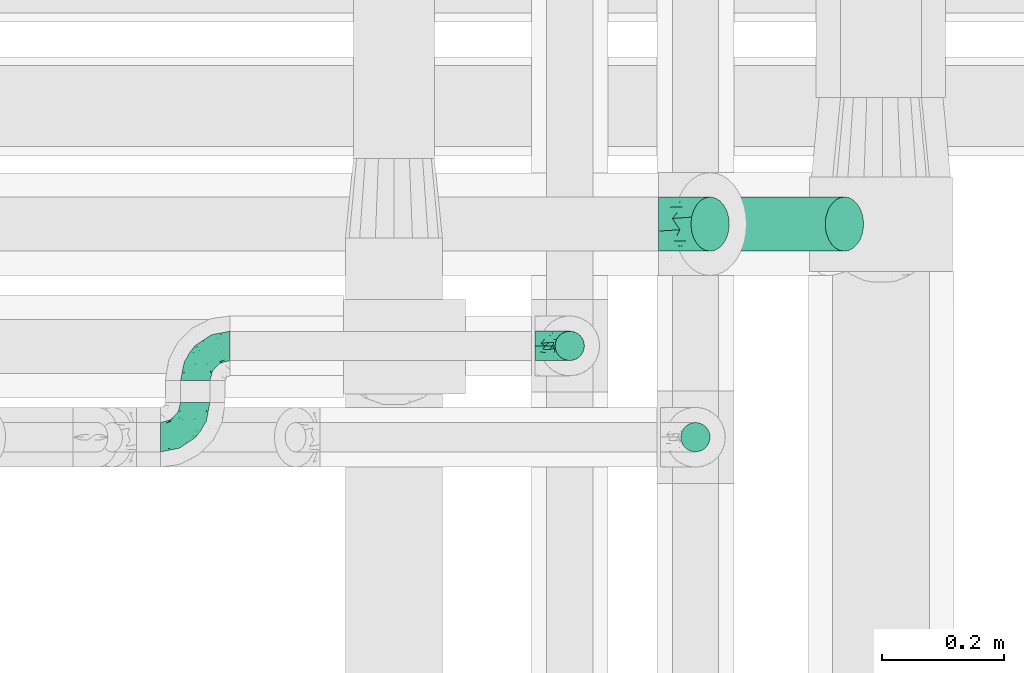
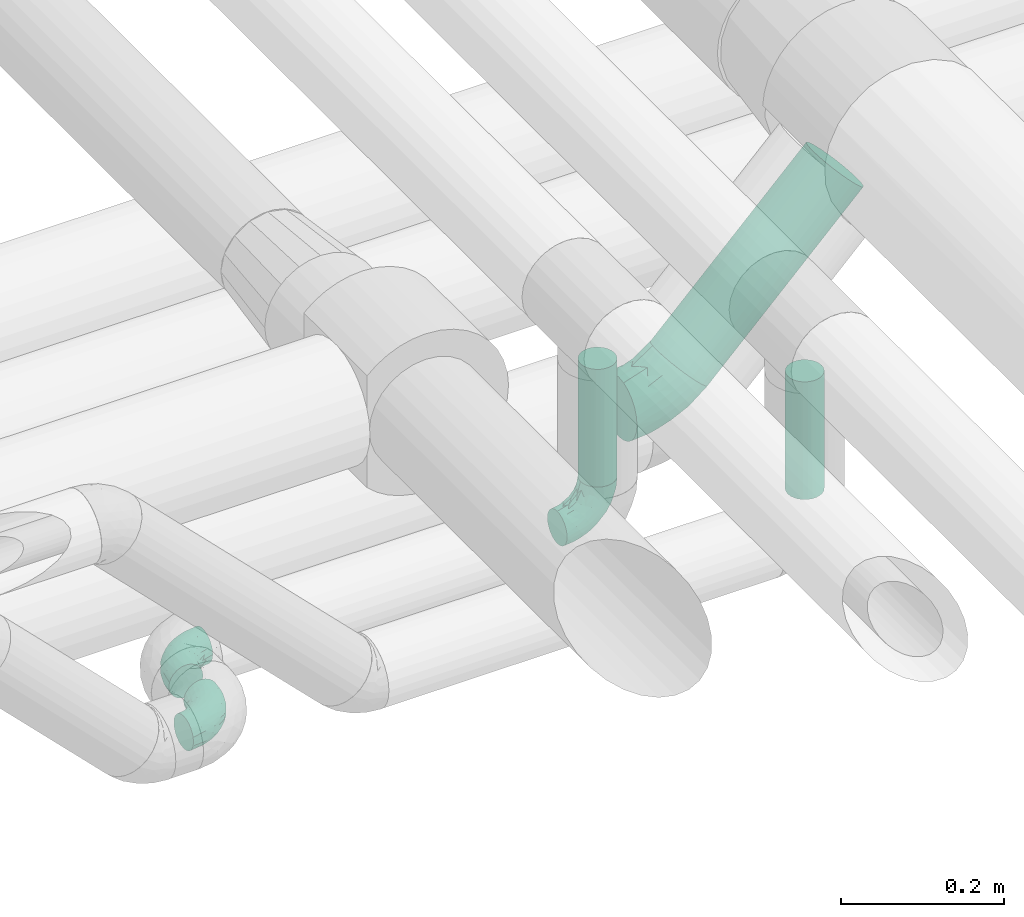
# One storey, part 67 of 93: 4 flow fittings, 3 flow segments.
"""IFC2X3 building model written with IfcOpenShell, lengths in millimetres."""

from ifc_helpers import new_model, entity, si_unit, converted_unit, derived_unit, direction, frame, origin, origin_2d_with_axis, place, context, subcontext, project, spatial, circle, extrude, faceted_brep, source, transform, mapped, material, type_object, type_shapes, element, save


model = new_model("IFC2X3")

# Units and contexts
model_context = context("Model", 3, precision=0.01, world=origin(), true_north=direction((6.12303176911189e-17, 1.0)))
body_context = subcontext(model_context, "Body", "Model", "MODEL_VIEW")
ifc_project = project(units=[si_unit("LENGTHUNIT", "METRE", prefix="MILLI"), si_unit("AREAUNIT", "SQUARE_METRE"), si_unit("VOLUMEUNIT", "CUBIC_METRE"), converted_unit("PLANEANGLEUNIT", "DEGREE", entity("IfcRatioMeasure", 0.0174532925199433), si_unit("PLANEANGLEUNIT", "RADIAN"), dimensions=[0, 0, 0, 0, 0, 0, 0]), si_unit("MASSUNIT", "GRAM", prefix="KILO"), derived_unit("MASSDENSITYUNIT", [(si_unit("MASSUNIT", "GRAM", prefix="KILO"), 1), (si_unit("LENGTHUNIT", "METRE"), -3)]), derived_unit("MOMENTOFINERTIAUNIT", [(si_unit("LENGTHUNIT", "METRE"), 4)]), si_unit("TIMEUNIT", "SECOND"), si_unit("FREQUENCYUNIT", "HERTZ"), si_unit("THERMODYNAMICTEMPERATUREUNIT", "DEGREE_CELSIUS"), derived_unit("THERMALTRANSMITTANCEUNIT", [(si_unit("MASSUNIT", "GRAM", prefix="KILO"), 1), (si_unit("THERMODYNAMICTEMPERATUREUNIT", "KELVIN"), -1), (si_unit("TIMEUNIT", "SECOND"), -3)]), derived_unit("VOLUMETRICFLOWRATEUNIT", [(si_unit("LENGTHUNIT", "METRE"), 3), (si_unit("TIMEUNIT", "SECOND"), -1)]), derived_unit("MASSFLOWRATEUNIT", [(si_unit("MASSUNIT", "GRAM", prefix="KILO"), 1), (si_unit("TIMEUNIT", "SECOND"), -1)]), derived_unit("ROTATIONALFREQUENCYUNIT", [(si_unit("TIMEUNIT", "SECOND"), -1)]), si_unit("ELECTRICCURRENTUNIT", "AMPERE"), si_unit("ELECTRICVOLTAGEUNIT", "VOLT"), si_unit("POWERUNIT", "WATT"), si_unit("FORCEUNIT", "NEWTON", prefix="KILO"), si_unit("ILLUMINANCEUNIT", "LUX"), si_unit("LUMINOUSFLUXUNIT", "LUMEN"), si_unit("LUMINOUSINTENSITYUNIT", "CANDELA"), derived_unit("USERDEFINED", [(si_unit("MASSUNIT", "GRAM", prefix="KILO"), -1), (si_unit("LENGTHUNIT", "METRE"), -2), (si_unit("TIMEUNIT", "SECOND"), 3), (si_unit("LUMINOUSFLUXUNIT", "LUMEN"), 1)]), derived_unit("LINEARVELOCITYUNIT", [(si_unit("LENGTHUNIT", "METRE"), 1), (si_unit("TIMEUNIT", "SECOND"), -1)]), si_unit("PRESSUREUNIT", "PASCAL"), derived_unit("USERDEFINED", [(si_unit("LENGTHUNIT", "METRE"), -2), (si_unit("MASSUNIT", "GRAM", prefix="KILO"), 1), (si_unit("TIMEUNIT", "SECOND"), -2)]), derived_unit("LINEARFORCEUNIT", [(si_unit("MASSUNIT", "GRAM", prefix="KILO"), 1), (si_unit("LENGTHUNIT", "METRE"), 1), (si_unit("TIMEUNIT", "SECOND"), -2), (si_unit("LENGTHUNIT", "METRE"), -1)]), derived_unit("PLANARFORCEUNIT", [(si_unit("MASSUNIT", "GRAM", prefix="KILO"), 1), (si_unit("LENGTHUNIT", "METRE"), 1), (si_unit("TIMEUNIT", "SECOND"), -2), (si_unit("LENGTHUNIT", "METRE"), -2)])], contexts=[model_context])

# Site, building, storey
site_placement = place(None, origin())
site = spatial("IfcSite", under=ifc_project, at=site_placement, CompositionType="ELEMENT")
building_placement = place(site_placement, origin())
building = spatial("IfcBuilding", under=site, at=building_placement, CompositionType="ELEMENT")
storey_placement = place(building_placement, frame((0.0, 0.0, -4200.0)))
storey = spatial("IfcBuildingStorey", under=building, at=storey_placement, CompositionType="ELEMENT", Elevation=-4200.0)

# Flow segments
pipe_segment_type_1 = type_object("IfcPipeSegmentType", PredefinedType="NOTDEFINED")
flow_segment_placement = place(storey_placement, frame((24665.5, 9015.05, 2689.95)))
element("IfcFlowSegment", 1, at=flow_segment_placement, inside=storey, type_object=pipe_segment_type_1, context=body_context, shape_type="SweptSolid", body=[
    extrude(circle(Radius=44.5, at=origin_2d_with_axis()), frame((33.06, 46.1, 33.06), z_axis=(0.707106781186488, 0.0, 0.707106781186607), x_axis=(0.0, -1.0, 0.0)), (0.0, 0.0, 1.0), 311.913103138138),
])
pipe_segment_type_2 = type_object("IfcPipeSegmentType", PredefinedType="NOTDEFINED")
for number, where in (
    (2, (24442.45, 8835.55, 2757.0)),
    (3, (24648.86, 8685.55, 2757.0)),
):
    element("IfcFlowSegment", number, at=place(storey_placement, frame(where)), inside=storey, type_object=pipe_segment_type_2, context=body_context, shape_type="SweptSolid", body=[
        extrude(circle(Radius=24.0, at=origin_2d_with_axis()), frame((25.6, 25.6, 0.0)), (0.0, 0.0, 1.0), 176.000000000013),
    ])

# Flow fittings
ifc_material = material()
pipe_fitting_type_1 = type_object("IfcPipeFittingType", Name="ADSK_2", PredefinedType="NOTDEFINED", material=ifc_material)
shared_shape_1 = source(origin(), body_context, "Body", "Brep", [
    faceted_brep([(-49.71, 22.25, -38.54), (-49.71, 11.52, -42.98), (-49.71, 0.0, -44.5), (-49.71, -11.52, -42.98), (-49.71, -22.25, -38.54), (-49.71, -31.47, -31.47), (-49.71, -38.54, -22.25), (-49.71, -42.98, -11.52), (-49.71, -44.5, 0.0), (-49.71, -42.98, 11.52), (-49.71, -38.54, 22.25), (-49.71, -31.47, 31.47), (-49.71, -22.25, 38.54), (-49.71, -11.52, 42.98), (-49.71, 0.0, 44.5), (-49.71, 11.52, 42.98), (-49.71, 22.25, 38.54), (-49.71, 31.47, 31.47), (-49.71, 38.54, 22.25), (-49.71, 42.98, 11.52), (-49.71, 44.5, 0.0), (-49.71, 42.98, -11.52), (-49.71, 38.54, -22.25), (-49.71, 31.47, -31.47), (7.9, 62.4, -22.25), (4.75, 65.54, -11.52), (3.68, 66.61, 0.0), (4.75, 65.54, 11.52), (7.9, 62.4, 22.25), (12.9, 57.4, 31.47), (19.41, 50.88, 38.54), (27.0, 43.29, 42.98), (35.15, 35.15, 44.5), (43.29, 27.0, 42.98), (50.88, 19.41, 38.54), (57.4, 12.9, 31.47), (62.4, 7.9, 22.25), (65.54, 4.75, 11.52), (66.61, 3.68, 0.0), (65.54, 4.75, -11.52), (62.4, 7.9, -22.25), (57.4, 12.9, -31.47), (50.88, 19.41, -38.54), (43.29, 27.0, -42.98), (35.15, 35.15, -44.5), (27.0, 43.29, -42.98), (19.41, 50.88, -38.54), (12.9, 57.4, -31.47), (-21.43, -33.27, 26.36), (-12.91, -37.31, 15.91), (10.17, -24.56, 25.5), (-27.71, -41.6, 0.0), (-7.13, -38.89, 0.0), (-18.38, -40.78, 7.83), (-14.74, -23.79, 34.6), (38.68, -8.37, 26.36), (6.12, -14.78, 36.19), (-25.19, -15.57, 40.8), (16.24, 25.94, 44.2), (-18.21, -2.89, 43.97), (-5.41, 13.06, 44.3), (-29.82, 6.86, 44.2), (27.25, -6.4, 34.6), (28.82, 6.8, 40.8), (-22.09, 19.83, 41.49), (-13.73, 33.15, 36.12), (12.63, -28.35, 17.49), (12.91, -31.18, 8.74), (-24.73, 38.45, 27.84), (-19.34, 46.69, 18.1), (41.83, -15.84, 7.83), (49.01, -9.83, 0.0), (-20.81, 50.25, 0.0), (14.92, 10.84, 43.97), (3.35, -8.1, 40.4), (-3.82, 48.3, 27.64), (35.51, -17.26, 15.91), (4.26, 31.34, 41.45), (-14.33, 52.2, 9.25), (12.71, -30.68, 0.0), (32.54, -22.46, 0.0), (-18.21, -2.89, -43.97), (-18.38, -40.78, -7.83), (12.91, -31.16, -8.82), (1.59, 29.64, -41.49), (-29.82, 6.86, -44.2), (-19.34, 46.69, -18.1), (27.25, -6.4, -34.6), (-13.73, 33.15, -36.12), (35.51, -17.26, -15.91), (-31.45, 36.86, -27.64), (14.92, 10.84, -43.97), (-26.78, 47.05, -9.25), (-25.18, 19.14, -41.45), (-12.91, -37.31, -15.91), (38.68, -8.37, -26.36), (-21.43, -33.27, -26.36), (10.17, -24.56, -25.5), (-14.74, -23.79, -34.6), (6.12, -14.78, -36.19), (3.35, -8.1, -40.4), (28.82, 6.8, -40.8), (-25.19, -15.57, -40.8), (-9.7, 44.68, -27.84), (41.83, -15.84, -7.83), (16.24, 25.94, -44.2), (-5.41, 13.06, -44.3), (10.98, -29.02, -17.53)], [[[0, 1, 2, 3, 4, 5, 6, 7, 8, 9, 10, 11, 12, 13, 14, 15, 16, 17, 18, 19, 20, 21, 22, 23]], [[24, 25, 26, 27, 28, 29, 30, 31, 32, 33, 34, 35, 36, 37, 38, 39, 40, 41, 42, 43, 44, 45, 46, 47]], [[48, 49, 50]], [[51, 52, 53]], [[12, 11, 54]], [[36, 35, 55]], [[54, 56, 57]], [[48, 11, 10]], [[32, 31, 58]], [[13, 12, 57]], [[59, 60, 61]], [[14, 13, 59]], [[62, 55, 35]], [[34, 33, 63]], [[61, 15, 14]], [[16, 64, 65]], [[9, 51, 53]], [[30, 29, 65]], [[66, 49, 67]], [[65, 17, 16]], [[18, 17, 68]], [[18, 68, 69]], [[19, 18, 69]], [[37, 70, 71]], [[19, 72, 20]], [[52, 67, 53]], [[49, 53, 67]], [[16, 15, 64]], [[32, 58, 73]], [[35, 34, 62]], [[74, 73, 59]], [[73, 33, 32]], [[75, 65, 29]], [[76, 36, 55]], [[60, 58, 77]], [[62, 34, 63]], [[17, 65, 68]], [[70, 37, 76]], [[49, 48, 10]], [[61, 64, 15]], [[56, 50, 62]], [[19, 69, 78]], [[10, 9, 49]], [[72, 78, 26]], [[48, 54, 11]], [[27, 78, 69]], [[74, 63, 73]], [[69, 68, 75]], [[55, 62, 50]], [[28, 75, 29]], [[57, 59, 13]], [[31, 30, 77]], [[77, 65, 64]], [[56, 74, 57]], [[60, 59, 73]], [[76, 37, 36]], [[54, 48, 50]], [[28, 27, 69]], [[76, 55, 50]], [[65, 77, 30]], [[60, 77, 64]], [[54, 57, 12]], [[59, 57, 74]], [[73, 63, 33]], [[63, 74, 56]], [[9, 8, 51]], [[67, 52, 79, 80]], [[9, 53, 49]], [[70, 67, 80]], [[67, 76, 66]], [[71, 70, 80]], [[71, 38, 37]], [[67, 70, 76]], [[59, 61, 14]], [[64, 61, 60]], [[77, 58, 31]], [[73, 58, 60]], [[69, 75, 28]], [[65, 75, 68]], [[26, 78, 27]], [[19, 78, 72]], [[50, 56, 54]], [[63, 56, 62]], [[76, 50, 66]], [[49, 66, 50]], [[81, 3, 2]], [[52, 82, 83]], [[46, 45, 84]], [[2, 1, 85]], [[86, 22, 21]], [[42, 41, 87]], [[88, 0, 23]], [[40, 39, 89]], [[22, 90, 23]], [[44, 43, 91]], [[86, 21, 92]], [[93, 1, 0]], [[82, 7, 94]], [[89, 95, 40]], [[94, 96, 97]], [[96, 94, 6]], [[5, 4, 98]], [[99, 100, 101]], [[7, 6, 94]], [[5, 96, 6]], [[102, 4, 3]], [[90, 88, 23]], [[98, 96, 5]], [[24, 47, 103]], [[20, 72, 92]], [[47, 88, 103]], [[72, 26, 25]], [[99, 97, 98]], [[88, 84, 93]], [[24, 86, 25]], [[47, 46, 88]], [[102, 98, 4]], [[84, 88, 46]], [[103, 90, 86]], [[85, 81, 2]], [[103, 86, 24]], [[39, 71, 104]], [[105, 45, 44]], [[101, 43, 42]], [[7, 82, 51]], [[40, 95, 41]], [[101, 87, 99]], [[95, 87, 41]], [[106, 105, 91]], [[97, 95, 89]], [[106, 91, 81]], [[104, 71, 80]], [[101, 91, 43]], [[100, 102, 81]], [[82, 94, 83]], [[100, 81, 91]], [[107, 89, 83]], [[105, 84, 45]], [[25, 86, 92]], [[106, 85, 93]], [[96, 98, 97]], [[87, 95, 97]], [[88, 93, 0]], [[106, 93, 84]], [[81, 102, 3]], [[102, 100, 99]], [[87, 101, 42]], [[91, 101, 100]], [[51, 82, 52]], [[51, 8, 7]], [[107, 83, 94]], [[104, 83, 89]], [[83, 80, 79, 52]], [[39, 38, 71]], [[83, 104, 80]], [[39, 104, 89]], [[93, 85, 1]], [[81, 85, 106]], [[91, 105, 44]], [[84, 105, 106]], [[86, 90, 22]], [[88, 90, 103]], [[20, 92, 21]], [[25, 92, 72]], [[97, 99, 87]], [[102, 99, 98]], [[94, 97, 107]], [[89, 107, 97]]]),
])
type_shapes(pipe_fitting_type_1, [shared_shape_1])
flow_fitting_1_placement = place(storey_placement, frame((24663.41, 9061.14, 2687.87), z_axis=(0.0, -1.0, 0.0), x_axis=(1.0, 0.0, 0.0)))
element("IfcFlowFitting", 4, at=flow_fitting_1_placement, inside=storey, type_object=pipe_fitting_type_1, material=ifc_material, Name="ADSK_2", ObjectType="ADSK_2", context=body_context, shape_type="MappedRepresentation", body=[
    mapped(shared_shape_1, transform((0.0, 0.0, 0.0), scale=1.0)),
])
pipe_fitting_type_2 = type_object("IfcPipeFittingType", Name="ADSK_1", PredefinedType="NOTDEFINED", material=ifc_material)
shared_shape_2 = source(origin(), body_context, "Body", "Brep", [
    faceted_brep([(-57.0, 12.07, -20.91), (-57.0, 6.25, -23.33), (-57.0, 0.0, -24.15), (-57.0, -6.25, -23.33), (-57.0, -12.08, -20.91), (-57.0, -17.08, -17.08), (-57.0, -20.91, -12.08), (-57.0, -23.33, -6.25), (-57.0, -24.15, 0.0), (-57.0, -23.33, 6.25), (-57.0, -20.91, 12.07), (-57.0, -17.08, 17.08), (-57.0, -12.08, 20.91), (-57.0, -6.25, 23.33), (-57.0, 0.0, 24.15), (-57.0, 6.25, 23.33), (-57.0, 12.07, 20.91), (-57.0, 17.08, 17.08), (-57.0, 20.91, 12.07), (-57.0, 23.33, 6.25), (-57.0, 24.15, 0.0), (-57.0, 23.33, -6.25), (-57.0, 20.91, -12.08), (-57.0, 17.08, -17.08), (0.0, 57.0, -24.15), (-6.25, 57.0, -23.33), (-12.07, 57.0, -20.91), (-17.08, 57.0, -17.08), (-20.91, 57.0, -12.08), (-23.33, 57.0, -6.25), (-24.15, 57.0, 0.0), (-23.33, 57.0, 6.25), (-20.91, 57.0, 12.07), (-17.08, 57.0, 17.08), (-12.07, 57.0, 20.91), (-6.25, 57.0, 23.33), (0.0, 57.0, 24.15), (6.25, 57.0, 23.33), (12.08, 57.0, 20.91), (17.08, 57.0, 17.08), (20.91, 57.0, 12.07), (23.33, 57.0, 6.25), (24.15, 57.0, 0.0), (23.33, 57.0, -6.25), (20.91, 57.0, -12.08), (17.08, 57.0, -17.08), (12.08, 57.0, -20.91), (6.25, 57.0, -23.33), (14.9, 21.14, 6.17), (13.61, 24.64, 12.48), (6.23, 8.95, 8.98), (-41.47, -21.06, 0.0), (-41.92, -18.38, 13.72), (-24.64, -13.61, 12.48), (-37.37, -13.24, 18.15), (-6.8, -4.93, 8.18), (-21.76, -15.19, 6.22), (-12.78, -9.18, 0.0), (-37.73, -20.51, 7.75), (-7.38, 7.38, 20.24), (-23.37, -4.26, 20.42), (-11.9, -3.19, 15.86), (-42.14, -8.7, 21.82), (13.24, 37.37, 18.15), (9.33, 23.53, 16.85), (4.26, 23.37, 20.42), (2.77, 10.92, 15.55), (-29.46, 0.91, 23.52), (-44.13, 20.56, 15.69), (-39.25, 26.33, 10.88), (-49.02, 22.92, 9.96), (-34.58, 23.87, 17.15), (-15.8, 6.8, 22.81), (-8.67, 20.47, 23.88), (-18.12, 12.9, 24.08), (-48.29, 14.92, 19.65), (-44.06, -2.85, 23.78), (-9.23, 48.95, 22.58), (-3.78, 42.74, 24.07), (-40.34, 4.26, 24.09), (-44.02, 26.14, 5.46), (-44.04, 9.88, 22.74), (-4.95, 16.87, 22.52), (-2.75, 1.43, 12.5), (-25.48, 40.98, 10.71), (20.51, 37.73, 7.75), (18.38, 41.92, 13.72), (8.7, 42.14, 21.82), (-25.95, -17.97, 0.0), (2.85, 44.06, 23.78), (21.06, 41.47, 0.0), (17.97, 25.95, 0.0), (-24.04, -9.27, 17.13), (-33.26, 33.26, 5.86), (-28.55, 40.57, 0.0), (-40.57, 28.55, 0.0), (-25.29, 47.19, 4.06), (-27.01, 31.1, 16.77), (-15.7, 43.95, 19.9), (-20.27, 45.22, 15.61), (-30.53, 31.98, 12.64), (-11.28, 38.33, 22.92), (-9.97, 27.88, 24.09), (-20.15, 30.26, 21.25), (-31.25, 11.75, 23.64), (-28.75, 7.23, 24.15), (-29.53, 18.06, 22.27), (-28.44, 24.21, 20.02), (-37.55, 17.7, 20.26), (-15.88, 29.25, 22.99), (-20.82, 20.82, 23.44), (-0.91, 29.46, 23.52), (-13.5, -7.67, 12.04), (1.49, 1.56, 5.16), (8.86, 10.35, 4.59), (0.38, -0.38, 0.0), (9.18, 12.78, 0.0), (-37.37, -13.24, -18.15), (8.86, 10.35, -4.59), (-45.22, 20.27, -15.61), (-43.95, 15.7, -19.9), (-38.33, 11.28, -22.92), (-48.95, 9.23, -22.58), (-47.19, 25.29, -4.06), (-33.26, 33.26, -5.86), (18.38, 41.92, -13.72), (-30.26, 20.15, -21.25), (2.85, 44.06, -23.78), (-4.26, 40.34, -24.09), (-40.98, 25.48, -10.71), (-41.92, -18.38, -13.72), (9.25, 23.5, -16.92), (4.26, 23.37, -20.42), (13.24, 37.37, -18.15), (-37.73, -20.51, -7.75), (-11.75, 31.25, -23.64), (-7.23, 28.75, -24.15), (-12.9, 18.12, -24.08), (8.7, 42.14, -21.82), (-44.06, -2.85, -23.78), (-6.8, 15.8, -22.81), (-20.47, 8.67, -23.88), (-24.64, -13.61, -12.48), (-42.74, 3.78, -24.07), (-18.06, 29.53, -22.27), (-24.21, 28.44, -20.02), (-27.88, 9.97, -24.09), (-31.1, 27.01, -16.77), (-26.14, 44.02, -5.46), (14.9, 21.14, -6.17), (20.51, 37.73, -7.75), (-9.88, 44.04, -22.74), (-20.56, 44.13, -15.69), (-21.76, -15.19, -6.22), (-13.5, -7.67, -12.04), (-24.14, -9.76, -16.74), (-11.9, -3.19, -15.86), (-14.92, 48.29, -19.65), (-23.37, -4.26, -20.42), (-0.91, 29.46, -23.52), (-26.33, 39.25, -10.88), (-23.87, 34.58, -17.15), (-42.14, -8.7, -21.82), (-22.92, 49.02, -9.96), (13.61, 24.64, -12.48), (-31.98, 30.53, -12.64), (-16.87, 4.95, -22.52), (-17.7, 37.55, -20.26), (-29.25, 15.88, -22.99), (-20.82, 20.82, -23.44), (-29.46, 0.91, -23.52), (-7.38, 7.38, -20.24), (2.77, 10.92, -15.55), (6.23, 8.95, -8.98), (-6.8, -4.93, -8.18), (-2.81, 1.41, -12.54), (1.49, 1.56, -5.16)], [[[0, 1, 2, 3, 4, 5, 6, 7, 8, 9, 10, 11, 12, 13, 14, 15, 16, 17, 18, 19, 20, 21, 22, 23]], [[24, 25, 26, 27, 28, 29, 30, 31, 32, 33, 34, 35, 36, 37, 38, 39, 40, 41, 42, 43, 44, 45, 46, 47]], [[48, 49, 50]], [[9, 8, 51]], [[52, 53, 54]], [[55, 56, 57]], [[10, 58, 52]], [[9, 58, 10]], [[59, 60, 61]], [[54, 12, 11]], [[54, 62, 12]], [[63, 39, 38]], [[64, 65, 66]], [[62, 60, 67]], [[68, 69, 70]], [[71, 69, 68]], [[72, 73, 74]], [[16, 75, 17]], [[13, 76, 14]], [[35, 77, 78]], [[14, 79, 15]], [[17, 68, 18]], [[14, 76, 79]], [[20, 19, 80]], [[70, 19, 18]], [[81, 15, 79]], [[15, 81, 16]], [[73, 72, 82]], [[66, 83, 50]], [[32, 31, 84]], [[85, 86, 49]], [[63, 87, 65]], [[56, 58, 88]], [[36, 89, 37]], [[85, 41, 40]], [[36, 35, 78]], [[90, 41, 85]], [[40, 39, 86]], [[12, 62, 13]], [[86, 85, 40]], [[48, 85, 49]], [[85, 91, 90]], [[87, 38, 37]], [[92, 60, 54]], [[80, 69, 93]], [[93, 94, 95]], [[10, 52, 11]], [[94, 96, 30]], [[97, 98, 99]], [[80, 93, 95]], [[100, 97, 84]], [[99, 98, 33]], [[101, 102, 78]], [[103, 101, 98]], [[96, 31, 30]], [[77, 98, 101]], [[77, 35, 34]], [[34, 33, 98]], [[9, 51, 58]], [[87, 63, 38]], [[104, 105, 74]], [[106, 103, 107]], [[106, 81, 104]], [[75, 68, 17]], [[108, 107, 71]], [[33, 32, 99]], [[109, 103, 110]], [[101, 109, 102]], [[89, 78, 111]], [[53, 52, 58]], [[54, 11, 52]], [[60, 62, 54]], [[88, 58, 51]], [[76, 62, 67]], [[53, 112, 92]], [[60, 59, 72]], [[39, 63, 86]], [[49, 86, 63]], [[89, 87, 37]], [[42, 41, 90]], [[111, 82, 65]], [[111, 65, 87]], [[65, 59, 66]], [[104, 81, 79]], [[75, 81, 108]], [[32, 84, 99]], [[97, 99, 84]], [[98, 97, 103]], [[106, 107, 108]], [[74, 102, 110]], [[111, 78, 102]], [[74, 110, 104]], [[74, 67, 72]], [[61, 92, 112]], [[66, 59, 61]], [[56, 53, 58]], [[66, 50, 49]], [[61, 112, 83]], [[66, 49, 64]], [[78, 89, 36]], [[87, 89, 111]], [[62, 76, 13]], [[79, 76, 67]], [[100, 93, 69]], [[96, 93, 84]], [[55, 113, 50]], [[113, 114, 50]], [[104, 79, 105]], [[106, 104, 110]], [[20, 80, 95]], [[85, 48, 91]], [[115, 114, 113]], [[116, 91, 48]], [[70, 80, 19]], [[93, 96, 94]], [[84, 31, 96]], [[103, 106, 110]], [[81, 106, 108]], [[103, 97, 107]], [[71, 107, 97]], [[71, 97, 100]], [[108, 71, 68]], [[79, 67, 105]], [[67, 74, 105]], [[115, 113, 57]], [[112, 56, 55]], [[56, 88, 57]], [[60, 72, 67]], [[82, 72, 59]], [[65, 82, 59]], [[82, 111, 73]], [[111, 102, 73]], [[102, 74, 73]], [[81, 75, 16]], [[68, 75, 108]], [[68, 70, 18]], [[80, 70, 69]], [[98, 77, 34]], [[78, 77, 101]], [[93, 100, 84]], [[71, 100, 69]], [[102, 109, 110]], [[101, 103, 109]], [[53, 92, 54]], [[61, 60, 92]], [[56, 112, 53]], [[83, 112, 55]], [[50, 83, 55]], [[61, 83, 66]], [[49, 63, 64]], [[65, 64, 63]], [[57, 113, 55]], [[114, 115, 116]], [[116, 48, 114]], [[48, 50, 114]], [[117, 5, 4]], [[116, 115, 118]], [[119, 120, 23]], [[121, 122, 120]], [[95, 123, 20]], [[0, 23, 120]], [[124, 95, 94]], [[125, 45, 44]], [[121, 120, 126]], [[24, 127, 128]], [[22, 21, 129]], [[0, 122, 1]], [[5, 117, 130]], [[131, 132, 133]], [[134, 88, 51]], [[135, 136, 137]], [[6, 5, 130]], [[46, 138, 47]], [[139, 3, 2]], [[140, 141, 137]], [[6, 134, 7]], [[134, 130, 142]], [[143, 2, 1]], [[144, 126, 145]], [[121, 146, 143]], [[147, 120, 119]], [[94, 148, 124]], [[149, 150, 91]], [[30, 29, 148]], [[151, 25, 128]], [[27, 152, 28]], [[134, 153, 88]], [[154, 155, 156]], [[27, 26, 157]], [[151, 26, 25]], [[155, 158, 156]], [[24, 47, 127]], [[1, 122, 143]], [[138, 132, 159]], [[160, 152, 161]], [[24, 128, 25]], [[46, 133, 138]], [[162, 117, 4]], [[148, 160, 124]], [[152, 160, 163]], [[154, 142, 155]], [[45, 125, 133]], [[133, 46, 45]], [[125, 164, 133]], [[51, 7, 134]], [[42, 90, 43]], [[165, 147, 129]], [[153, 134, 142]], [[43, 150, 44]], [[162, 4, 3]], [[141, 140, 166]], [[117, 162, 158]], [[163, 29, 28]], [[43, 90, 150]], [[123, 21, 20]], [[144, 151, 135]], [[157, 152, 27]], [[167, 145, 161]], [[23, 22, 119]], [[168, 126, 169]], [[121, 168, 146]], [[139, 143, 170]], [[142, 130, 117]], [[8, 7, 51]], [[134, 6, 130]], [[139, 162, 3]], [[170, 166, 158]], [[170, 158, 162]], [[158, 171, 156]], [[44, 150, 125]], [[91, 150, 90]], [[164, 125, 150]], [[132, 138, 133]], [[127, 138, 159]], [[131, 164, 172]], [[132, 171, 140]], [[135, 151, 128]], [[157, 151, 167]], [[22, 129, 119]], [[147, 119, 129]], [[120, 147, 126]], [[144, 145, 167]], [[137, 146, 169]], [[170, 143, 146]], [[137, 169, 135]], [[137, 159, 140]], [[171, 172, 156]], [[173, 174, 175]], [[156, 175, 154]], [[174, 57, 153]], [[132, 172, 171]], [[172, 164, 173]], [[143, 139, 2]], [[162, 139, 170]], [[138, 127, 47]], [[128, 127, 159]], [[165, 124, 160]], [[123, 124, 129]], [[149, 173, 164]], [[176, 174, 173]], [[135, 128, 136]], [[144, 135, 169]], [[150, 149, 164]], [[176, 118, 115]], [[149, 91, 116]], [[30, 148, 94]], [[163, 148, 29]], [[124, 123, 95]], [[129, 21, 123]], [[126, 144, 169]], [[151, 144, 167]], [[126, 147, 145]], [[161, 145, 147]], [[161, 147, 165]], [[167, 161, 152]], [[128, 159, 136]], [[159, 137, 136]], [[154, 153, 142]], [[132, 140, 159]], [[174, 176, 57]], [[57, 88, 153]], [[166, 140, 171]], [[158, 166, 171]], [[166, 170, 141]], [[170, 146, 141]], [[146, 137, 141]], [[151, 157, 26]], [[152, 157, 167]], [[152, 163, 28]], [[148, 163, 160]], [[120, 122, 0]], [[143, 122, 121]], [[124, 165, 129]], [[161, 165, 160]], [[146, 168, 169]], [[121, 126, 168]], [[142, 117, 155]], [[158, 155, 117]], [[175, 156, 172]], [[153, 154, 174]], [[173, 175, 172]], [[174, 154, 175]], [[164, 131, 133]], [[172, 132, 131]], [[176, 173, 118]], [[57, 176, 115]], [[173, 149, 118]], [[149, 116, 118]]]),
])
type_shapes(pipe_fitting_type_2, [shared_shape_2])
for number, where, z_axis, x_axis, name in (
    (5, (24468.05, 8861.14, 2700.0), (0.0, 1.0, 0.0), (0.0, 0.0, -1.0), "ADSK_1"),
    (6, (23853.05, 8861.14, 2700.0), (0.0, 0.0, 1.0), (-1.0, 0.0, 0.0), "ADSK_1"),
):
    element("IfcFlowFitting", number, at=place(storey_placement, frame(where, z_axis=z_axis, x_axis=x_axis)), inside=storey, type_object=pipe_fitting_type_2, material=ifc_material, Name=name, ObjectType="ADSK_1", context=body_context, shape_type="MappedRepresentation", body=[
        mapped(shared_shape_2, transform((0.0, 0.0, 0.0), scale=1.0)),
    ])
flow_fitting_2_placement = place(storey_placement, frame((23853.05, 8711.14, 2700.0)))
element("IfcFlowFitting", 7, at=flow_fitting_2_placement, inside=storey, type_object=pipe_fitting_type_2, material=ifc_material, Name="ADSK_1", ObjectType="ADSK_1", context=body_context, shape_type="MappedRepresentation", body=[
    mapped(shared_shape_2, transform((0.0, 0.0, 0.0), scale=1.0)),
])

save(model, "model.ifc")
